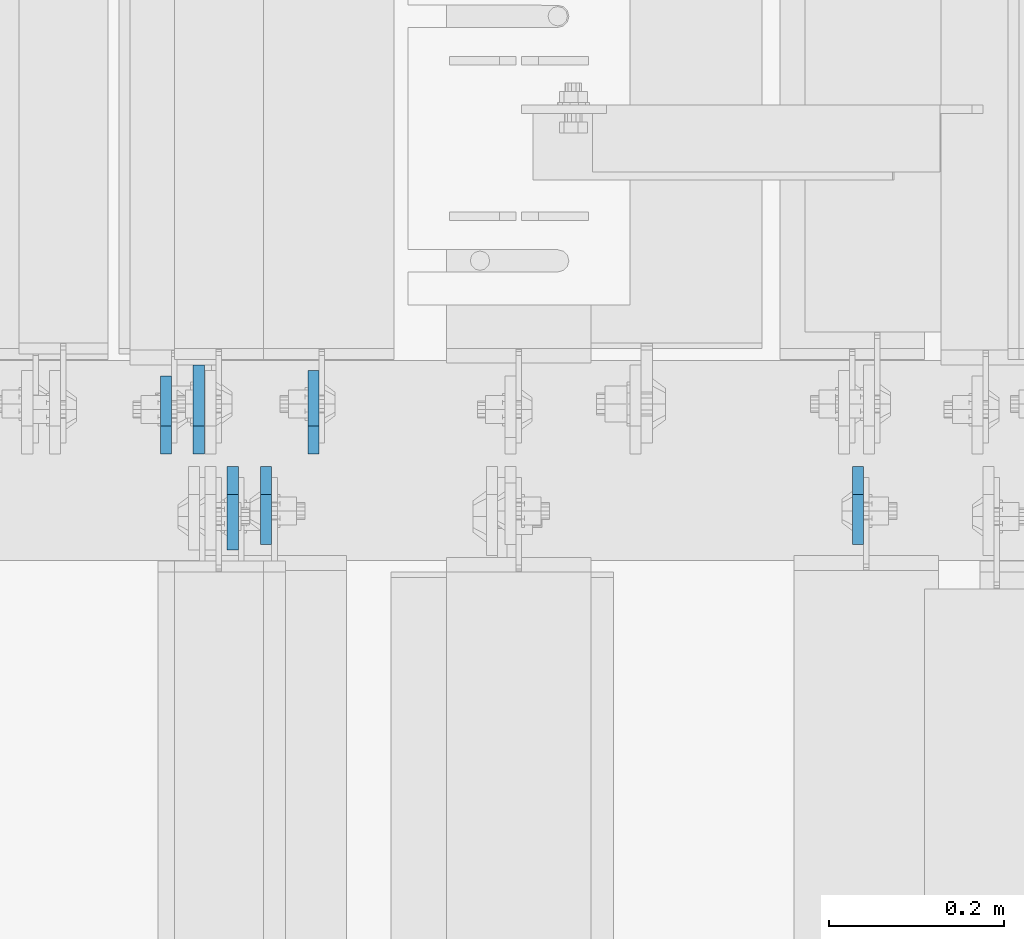
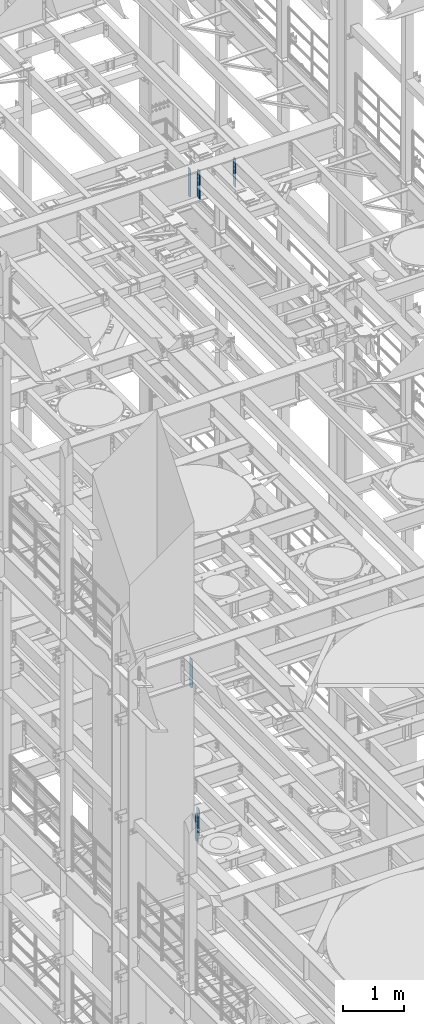
# One storey, part 1724 of 1876: 6 plates, 3 elements without a shape of their own.
"""IFC2X3 building model written with IfcOpenShell, lengths in millimetres."""

from ifc_helpers import new_model, si_unit, frame, origin_with_axes, place, context, subcontext, project, spatial, faceted_brep, material, type_object, element, aggregate, save


model = new_model("IFC2X3")

# Units and contexts
model_context = context("Model", 3, precision=1e-05, world=origin_with_axes())
body_context = subcontext(model_context, "Body", "Model", "MODEL_VIEW")
ifc_project = project(units=[si_unit("LENGTHUNIT", "METRE", prefix="MILLI"), si_unit("AREAUNIT", "SQUARE_METRE"), si_unit("VOLUMEUNIT", "CUBIC_METRE"), si_unit("MASSUNIT", "GRAM", prefix="KILO"), si_unit("TIMEUNIT", "SECOND"), si_unit("PLANEANGLEUNIT", "RADIAN"), si_unit("SOLIDANGLEUNIT", "STERADIAN"), si_unit("THERMODYNAMICTEMPERATUREUNIT", "DEGREE_CELSIUS"), si_unit("LUMINOUSINTENSITYUNIT", "LUMEN")], contexts=[model_context])

# Site, building, storey
site_placement = place(None, origin_with_axes())
site = spatial("IfcSite", under=ifc_project, at=site_placement, CompositionType="ELEMENT")
building_placement = place(site_placement, origin_with_axes())
building = spatial("IfcBuilding", under=site, at=building_placement, Name="Undefined", CompositionType="ELEMENT")
storey_placement = place(building_placement, origin_with_axes())
storey = spatial("IfcBuildingStorey", under=building, at=storey_placement, Name="Undefined", CompositionType="ELEMENT", Elevation=0.0)

# Assembly, plates
assembly_1_placement = place(storey_placement, origin_with_axes())
assembly_1 = element("IfcElementAssembly", 1, at=assembly_1_placement, inside=storey, Name="BEAM", AssemblyPlace="NOTDEFINED", PredefinedType="RIGID_FRAME")
ifc_material = material(Name="STEEL/A36")
plate_type_1 = type_object("IfcPlateType", PredefinedType="NOTDEFINED")
plate_1_placement = place(assembly_1_placement, frame((5492.74999990463, 7612.85625, 17386.3), z_axis=(0.0, 0.0, 1.0), x_axis=(0.0, -1.0, 0.0)))
plate_1 = element("IfcPlate", 2, at=plate_1_placement, type_object=plate_type_1, material=ifc_material, Name="PLATE", context=body_context, shape_type="Brep", body=[
    faceted_brep([(0.0, -6.34999999999991, 31.75), (0.0, -6.34999999999991, 539.75), (0.0, 6.34999999999991, 539.75), (0.0, 6.34999999999991, 31.75), (31.75, -6.34999999999991, 571.5), (31.75, 6.34999999999991, 571.5), (88.9000015258789, -6.34999999999991, 571.5), (88.9000015258789, 6.34999999999991, 571.5), (88.9000015258789, -6.34999999999991, 0.0), (88.9000015258789, 6.34999999999991, 0.0), (31.75, -6.34999999999991, 0.0), (31.75, 6.34999999999991, 0.0)], [[[0, 1, 2, 3]], [[1, 4, 5, 2]], [[4, 6, 7, 5]], [[6, 8, 9, 7]], [[8, 10, 11, 9]], [[10, 0, 3, 11]], [[5, 7, 9, 11, 3, 2]], [[10, 8, 6, 4, 1, 0]]]),
])
plate_2_placement = place(assembly_1_placement, frame((4816.47499990463, 7612.85625, 17386.3), z_axis=(0.0, 0.0, 1.0), x_axis=(0.0, -1.0, 0.0)))
plate_2 = element("IfcPlate", 3, at=plate_2_placement, type_object=plate_type_1, material=ifc_material, Name="PLATE", context=body_context, shape_type="Brep", body=[
    faceted_brep([(0.0, -6.34999999999991, 31.75), (0.0, -6.34999999999991, 539.75), (0.0, 6.34999999999991, 539.75), (0.0, 6.34999999999991, 31.75), (31.75, -6.34999999999991, 571.5), (31.75, 6.34999999999991, 571.5), (88.9000015258789, -6.34999999999991, 571.5), (88.9000015258789, 6.34999999999991, 571.5), (88.9000015258789, -6.34999999999991, 0.0), (88.9000015258789, 6.34999999999991, 0.0), (31.75, -6.34999999999991, 0.0), (31.75, 6.34999999999991, 0.0)], [[[0, 1, 2, 3]], [[1, 4, 5, 2]], [[4, 6, 7, 5]], [[6, 8, 9, 7]], [[8, 10, 11, 9]], [[10, 0, 3, 11]], [[5, 7, 9, 11, 3, 2]], [[10, 8, 6, 4, 1, 0]]]),
])
plate_3_placement = place(assembly_1_placement, frame((4702.17499990463, 7627.14375, 17386.3), z_axis=(0.0, 0.0, 1.0), x_axis=(0.0, 1.0, 0.0)))
plate_3 = element("IfcPlate", 4, at=plate_3_placement, type_object=plate_type_1, material=ifc_material, Name="PLATE", context=body_context, shape_type="Brep", body=[
    faceted_brep([(0.0, -6.34999999999991, 31.75), (0.0, -6.34999999999991, 539.75), (0.0, 6.34999999999991, 539.75), (0.0, 6.34999999999991, 31.75), (31.75, -6.34999999999991, 571.5), (31.75, 6.34999999999991, 571.5), (88.9000015258789, -6.34999999999991, 571.5), (88.9000015258789, 6.34999999999991, 571.5), (88.9000015258789, -6.34999999999991, 0.0), (88.9000015258789, 6.34999999999991, 0.0), (31.75, -6.34999999999991, 0.0), (31.75, 6.34999999999991, 0.0)], [[[0, 1, 2, 3]], [[1, 4, 5, 2]], [[4, 6, 7, 5]], [[6, 8, 9, 7]], [[8, 10, 11, 9]], [[10, 0, 3, 11]], [[5, 7, 9, 11, 3, 2]], [[10, 8, 6, 4, 1, 0]]]),
])
aggregate(assembly_1, [plate_1, plate_2, plate_3])

assembly_2_placement = place(storey_placement, origin_with_axes())
assembly_2 = element("IfcElementAssembly", 5, at=assembly_2_placement, inside=storey, Name="BEAM", AssemblyPlace="NOTDEFINED", PredefinedType="RIGID_FRAME")
plate_type_2 = type_object("IfcPlateType", PredefinedType="NOTDEFINED")
plate_4_placement = place(assembly_2_placement, frame((4778.37499990463, 7612.85625, 4535.4875), z_axis=(0.0, 0.0, 1.0), x_axis=(0.0, -1.0, 0.0)))
plate_4 = element("IfcPlate", 6, at=plate_4_placement, type_object=plate_type_2, material=ifc_material, Name="PLATE", context=body_context, shape_type="Brep", body=[
    faceted_brep([(0.0, -6.34999999999991, 31.75), (0.0, -6.35000000000036, 538.162475585938), (0.0, 6.35000000000036, 538.162475585938), (0.0, 6.34999999999991, 31.75), (31.75, -6.35000000000036, 569.912475585938), (31.75, 6.35000000000036, 569.912475585938), (95.25, -6.35000000000036, 569.912475585938), (95.25, 6.35000000000036, 569.912475585938), (95.25, -6.35000000000036, 0.0), (95.25, 6.35000000000036, 0.0), (31.75, -6.34999999999991, 0.0), (31.75, 6.34999999999991, 0.0)], [[[0, 1, 2, 3]], [[1, 4, 5, 2]], [[4, 6, 7, 5]], [[6, 8, 9, 7]], [[8, 10, 11, 9]], [[10, 0, 3, 11]], [[5, 7, 9, 11, 3, 2]], [[10, 8, 6, 4, 1, 0]]]),
])
plate_5_placement = place(assembly_2_placement, frame((4870.44999990463, 7627.14375, 4535.4875), z_axis=(0.0, 0.0, 1.0), x_axis=(0.0, 1.0, 0.0)))
plate_5 = element("IfcPlate", 7, at=plate_5_placement, type_object=plate_type_2, material=ifc_material, Name="PLATE", context=body_context, shape_type="Brep", body=[
    faceted_brep([(0.0, -6.34999999999991, 31.75), (0.0, -6.35000000000036, 538.162475585938), (0.0, 6.35000000000036, 538.162475585938), (0.0, 6.34999999999991, 31.75), (31.75, -6.35000000000036, 569.912475585938), (31.75, 6.35000000000036, 569.912475585938), (95.25, -6.35000000000036, 569.912475585938), (95.25, 6.35000000000036, 569.912475585938), (95.25, -6.35000000000036, 0.0), (95.25, 6.35000000000036, 0.0), (31.75, -6.34999999999991, 0.0), (31.75, 6.34999999999991, 0.0)], [[[0, 1, 2, 3]], [[1, 4, 5, 2]], [[4, 6, 7, 5]], [[6, 8, 9, 7]], [[8, 10, 11, 9]], [[10, 0, 3, 11]], [[5, 7, 9, 11, 3, 2]], [[10, 8, 6, 4, 1, 0]]]),
])
aggregate(assembly_2, [plate_4, plate_5])

# Assembly, plate
assembly_3_placement = place(storey_placement, origin_with_axes())
assembly_3 = element("IfcElementAssembly", 8, at=assembly_3_placement, inside=storey, Name="BEAM", AssemblyPlace="NOTDEFINED", PredefinedType="RIGID_FRAME")
plate_type_3 = type_object("IfcPlateType", PredefinedType="NOTDEFINED")
plate_6_placement = place(assembly_3_placement, frame((4739.48124990463, 7627.14375, 7558.0875), z_axis=(0.0, 0.0, 1.0), x_axis=(0.0, 1.0, 0.0)))
plate_6 = element("IfcPlate", 9, at=plate_6_placement, type_object=plate_type_3, material=ifc_material, Name="PLATE", context=body_context, shape_type="Brep", body=[
    faceted_brep([(0.0, -6.34999999999991, 31.75), (0.0, -6.35000000000036, 538.162475585938), (0.0, 6.35000000000036, 538.162475585938), (0.0, 6.34999999999991, 31.75), (31.75, -6.35000000000036, 569.912475585938), (31.75, 6.35000000000036, 569.912475585938), (101.599998474121, -6.34999999999991, 569.912475585938), (101.599998474121, 6.34999999999991, 569.912475585938), (101.599998474121, -6.35000000000036, 0.0), (101.599998474121, 6.35000000000036, 0.0), (31.75, -6.34999999999991, 0.0), (31.75, 6.34999999999991, 0.0)], [[[0, 1, 2, 3]], [[1, 4, 5, 2]], [[4, 6, 7, 5]], [[6, 8, 9, 7]], [[8, 10, 11, 9]], [[10, 0, 3, 11]], [[5, 7, 9, 11, 3, 2]], [[10, 8, 6, 4, 1, 0]]]),
])
aggregate(assembly_3, [plate_6])

save(model, "model.ifc")
